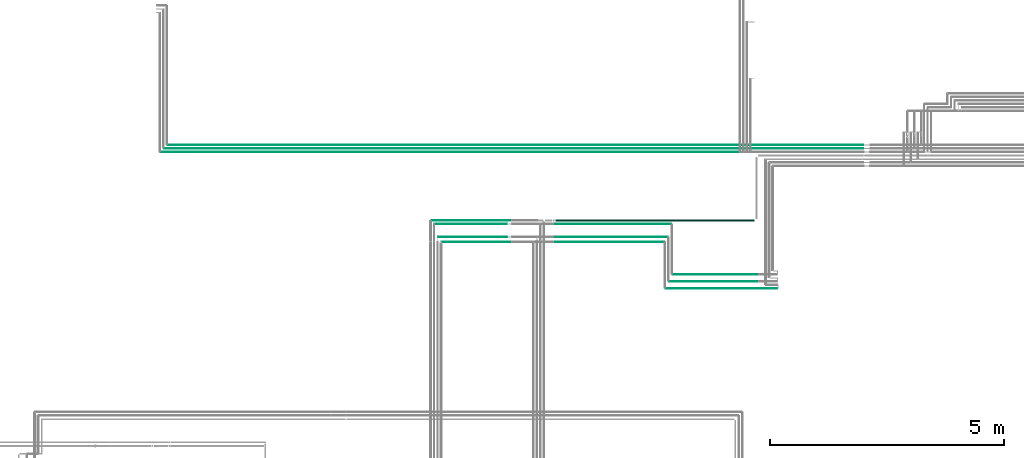
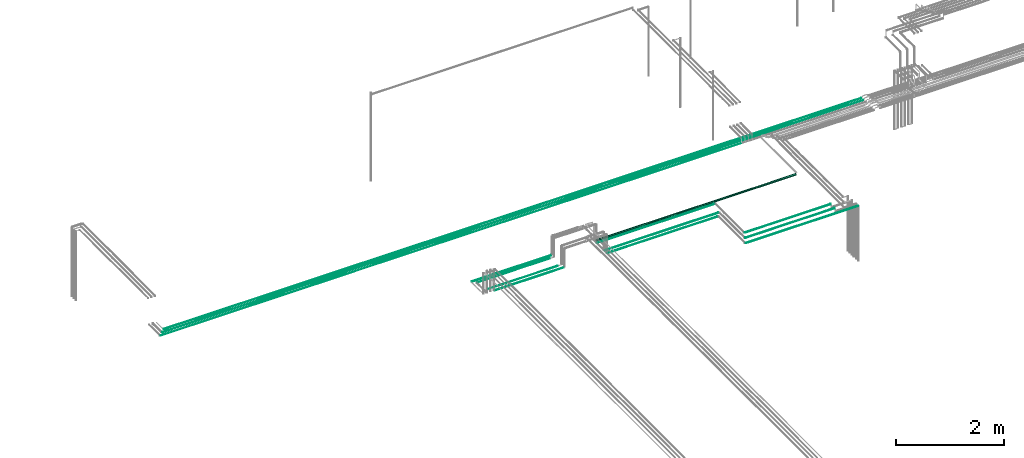
# One storey, part 23 of 331: 14 flow segments.
"""IFC2X3 building model written with IfcOpenShell, lengths in millimetres."""

import ifcopenshell
import ifcopenshell.guid

model = None  # the IFC model being written
_history = None  # IfcOwnerHistory: only IFC2X3 demands one
_inside = {}  # id of a spatial element -> (the spatial element, [elements in it])
_under = {}  # id of a project, library or spatial element -> (it, [spatial elements below it])
_declared = {}  # id of a project -> (the project, [libraries it declares])
_typed = {}  # id of a type object -> (the type object, [elements of that type])
_made_of = {}  # id of a material, layer set ... -> (it, [elements and type objects made of it])


def new_model(schema):
    """Start an empty IFC model of exactly this schema.

    Asked for "IFC4X3", IfcOpenShell would pick the latest addendum, in which some entities
    have other attributes; the version numbers below select the first issue.
    IFC2X3 requires an IfcOwnerHistory on every rooted entity: one is made here for all.
    """
    global model, _history
    if schema == "IFC4X3":
        model = ifcopenshell.file(schema_version=(4, 3, 0, 0))
    else:
        model = ifcopenshell.file(schema=schema)
    _inside.clear()
    _under.clear()
    _declared.clear()
    _typed.clear()
    _made_of.clear()
    _history = None
    if model.schema == "IFC2X3":
        org = make("IfcOrganization", Name="unknown")
        user = make(
            "IfcPersonAndOrganization",
            ThePerson=make("IfcPerson", FamilyName="unknown"),
            TheOrganization=org,
        )
        app = make(
            "IfcApplication",
            ApplicationDeveloper=org,
            Version="unknown",
            ApplicationFullName="unknown",
            ApplicationIdentifier="unknown",
        )
        _history = make(
            "IfcOwnerHistory",
            OwningUser=user,
            OwningApplication=app,
            ChangeAction="ADDED",
            CreationDate=0,
        )
    return model


def make(cls, **values):
    """One entity of the class cls with the attributes given. An attribute that is None is left unset."""
    return model.create_entity(
        cls, **{name: value for name, value in values.items() if value is not None}
    )


def entity(cls, *values):
    """Any entity or typed value of the class cls, its attributes in the order of the schema. None: left unset."""
    e = model.create_entity(cls)
    for i, value in enumerate(values):
        if value is not None:
            e[i] = value
    return e


def rooted(cls, **values):
    """An entity with a GlobalId (a new one), such as an element, a storey or a relation."""
    return make(cls, GlobalId=ifcopenshell.guid.new(), OwnerHistory=_history, **values)


def si_unit(unit_type, name, prefix=None):
    """IfcSIUnit, for example si_unit("LENGTHUNIT", "METRE", prefix="MILLI")."""
    return make("IfcSIUnit", UnitType=unit_type, Prefix=prefix, Name=name)


def converted_unit(unit_type, name, factor, base, dimensions=None, offset=None):
    """IfcConversionBasedUnit, such as the inch: factor (a typed value) times the base unit."""
    return make(
        "IfcConversionBasedUnit"
        if offset is None
        else "IfcConversionBasedUnitWithOffset",
        ConversionOffset=offset,
        Dimensions=None
        if dimensions is None
        else entity("IfcDimensionalExponents", *dimensions),
        UnitType=unit_type,
        Name=name,
        ConversionFactor=make(
            "IfcMeasureWithUnit", ValueComponent=factor, UnitComponent=base
        ),
    )


def derived_unit(unit_type, elements):
    """IfcDerivedUnit: a product of units, each with its exponent."""
    return make(
        "IfcDerivedUnit",
        Elements=[
            make("IfcDerivedUnitElement", Unit=unit, Exponent=power)
            for unit, power in elements
        ],
        UnitType=unit_type,
    )


def assignment(units):
    """IfcUnitAssignment: the units of a project."""
    return None if units is None else make("IfcUnitAssignment", Units=units)


def point(xyz):
    """IfcCartesianPoint."""
    return None if xyz is None else make("IfcCartesianPoint", Coordinates=xyz)


def direction(xyz):
    """IfcDirection."""
    return None if xyz is None else make("IfcDirection", DirectionRatios=xyz)


def frame(location, z_axis=None, x_axis=None):
    """IfcAxis2Placement3D, a coordinate frame: its origin and axes. An axis left out is left unset."""
    return make(
        "IfcAxis2Placement3D",
        Location=point(location),
        Axis=direction(z_axis),
        RefDirection=direction(x_axis),
    )


def frame_2d(location, x_axis=None):
    """IfcAxis2Placement2D, a coordinate frame in the plane: its origin and x axis."""
    return make(
        "IfcAxis2Placement2D", Location=point(location), RefDirection=direction(x_axis)
    )


def origin():
    """The frame at (0, 0, 0) with its axes left unset."""
    return frame((0.0, 0.0, 0.0))


def origin_2d_with_axis():
    """The frame at (0, 0) in the plane with the x axis (1, 0) written out."""
    return frame_2d((0.0, 0.0), x_axis=(1.0, 0.0))


def place(relative_to, where):
    """IfcLocalPlacement: puts the frame where relative to a parent placement (None: the world)."""
    return make(
        "IfcLocalPlacement", PlacementRelTo=relative_to, RelativePlacement=where
    )


def context(
    kind, dimensions, precision=None, world=None, true_north=None, identifier=None
):
    """IfcGeometricRepresentationContext, for example the 3D "Model" context."""
    return make(
        "IfcGeometricRepresentationContext",
        ContextIdentifier=identifier,
        ContextType=kind,
        CoordinateSpaceDimension=dimensions,
        Precision=precision,
        WorldCoordinateSystem=world,
        TrueNorth=true_north,
    )


def subcontext(parent, identifier, kind, view, scale=None):
    """IfcGeometricRepresentationSubContext, for example "Body" below "Model"."""
    return make(
        "IfcGeometricRepresentationSubContext",
        ContextIdentifier=identifier,
        ContextType=kind,
        ParentContext=parent,
        TargetScale=scale,
        TargetView=view,
    )


def project(units=None, contexts=None):
    """IfcProject with its units and contexts."""
    return rooted(
        "IfcProject",
        Name="project",
        RepresentationContexts=contexts,
        UnitsInContext=assignment(units),
    )


def spatial(cls, under=None, at=None, **own):
    """A site, building, storey or space (cls), placed at a placement, below another one or the project."""
    s = rooted(cls, ObjectPlacement=at, **own)
    if under is not None:
        _under.setdefault(under.id(), (under, []))[1].append(s)
    return s


def profile(cls, at=None, kind="AREA", **sizes):
    """A parametric profile (cls). Its sizes go by their IFC names, for example OverallWidth=200.0."""
    return make(cls, ProfileType=kind, Position=at, **sizes)


def circle(**sizes):
    """IfcCircleProfileDef."""
    return profile("IfcCircleProfileDef", **sizes)


def extrude(swept, where, along, depth):
    """IfcExtrudedAreaSolid: the profile swept, set in the frame where, extruded along a direction by depth."""
    return make(
        "IfcExtrudedAreaSolid",
        SweptArea=swept,
        Position=where,
        ExtrudedDirection=direction(along),
        Depth=depth,
    )


def shape(context_of_items, identifier, shape_type, items):
    """IfcShapeRepresentation: the items that make up one representation, for example the "Body"."""
    return make(
        "IfcShapeRepresentation",
        ContextOfItems=context_of_items,
        RepresentationIdentifier=identifier,
        RepresentationType=shape_type,
        Items=items,
    )


def made_of(thing, what):
    """Note that an element or type object is made of a material, layer set ...; save() writes the relation."""
    if what is not None:
        _made_of.setdefault(what.id(), (what, []))[1].append(thing)
    return thing


def type_object(cls, material=None, **own):
    """A type object (cls), such as IfcWallType, which elements share."""
    return made_of(rooted(cls, **own), material)


def element(
    cls,
    number,
    at=None,
    inside=None,
    cuts=None,
    type_object=None,
    material=None,
    context=None,
    identifier="Body",
    shape_type=None,
    held_by="IfcProductDefinitionShape",
    body=None,
    shapes=None,
    **own,
):
    """One element of the class cls, such as IfcWall. Its Tag is "e" and its number.

    at: its placement. inside: the storey or other place that contains it. cuts: it is an
    opening in that element (IfcRelVoidsElement). A single representation is given by context,
    identifier, shape_type and body (its items); several are given by shapes. held_by: the class
    of the entity that holds the representations. save() writes the other relations.
    """
    e = rooted(cls, Tag="e%d" % number, ObjectPlacement=at, **own)
    if body is not None:
        shapes = [shape(context, identifier, shape_type, body)]
    if shapes is not None:
        e.Representation = make(held_by, Representations=shapes)
    if inside is not None:
        _inside.setdefault(inside.id(), (inside, []))[1].append(e)
    if cuts is not None:
        rooted(
            "IfcRelVoidsElement", RelatingBuildingElement=cuts, RelatedOpeningElement=e
        )
    if type_object is not None:
        _typed.setdefault(type_object.id(), (type_object, []))[1].append(e)
    return made_of(e, material)


def aggregate(whole, parts):
    """IfcRelAggregates: a whole, such as a stair, and the parts it consists of."""
    return rooted("IfcRelAggregates", RelatingObject=whole, RelatedObjects=parts)


def save(model, path):
    """Write the relations noted so far, then the file.

    IfcRelAggregates (storeys below a building ...), IfcRelContainedInSpatialStructure (elements
    in a storey), IfcRelDefinesByType, IfcRelAssociatesMaterial and IfcRelDeclares: one each for
    every whole, place, type object, material and project.
    """
    for whole, parts in _under.values():
        aggregate(whole, parts)
    for where, things in _inside.values():
        rooted(
            "IfcRelContainedInSpatialStructure",
            RelatedElements=things,
            RelatingStructure=where,
        )
    for kind, things in _typed.values():
        rooted("IfcRelDefinesByType", RelatedObjects=things, RelatingType=kind)
    for what, things in _made_of.values():
        rooted("IfcRelAssociatesMaterial", RelatedObjects=things, RelatingMaterial=what)
    for by, libraries in _declared.values():
        rooted("IfcRelDeclares", RelatingContext=by, RelatedDefinitions=libraries)
    model.write(path)


model = new_model("IFC2X3")

# Units and contexts
model_context = context("Model", 3, precision=0.01, world=origin(), true_north=direction((6.12303176911189e-17, 1.0)))
body_context = subcontext(model_context, "Body", "Model", "MODEL_VIEW")
ifc_project = project(units=[si_unit("LENGTHUNIT", "METRE", prefix="MILLI"), si_unit("AREAUNIT", "SQUARE_METRE"), si_unit("VOLUMEUNIT", "CUBIC_METRE"), converted_unit("PLANEANGLEUNIT", "DEGREE", entity("IfcRatioMeasure", 0.0174532925199433), si_unit("PLANEANGLEUNIT", "RADIAN"), dimensions=[0, 0, 0, 0, 0, 0, 0]), si_unit("MASSUNIT", "GRAM", prefix="KILO"), derived_unit("MASSDENSITYUNIT", [(si_unit("MASSUNIT", "GRAM", prefix="KILO"), 1), (si_unit("LENGTHUNIT", "METRE"), -3)]), derived_unit("MOMENTOFINERTIAUNIT", [(si_unit("LENGTHUNIT", "METRE"), 4)]), si_unit("TIMEUNIT", "SECOND"), si_unit("FREQUENCYUNIT", "HERTZ"), si_unit("THERMODYNAMICTEMPERATUREUNIT", "DEGREE_CELSIUS"), derived_unit("THERMALTRANSMITTANCEUNIT", [(si_unit("MASSUNIT", "GRAM", prefix="KILO"), 1), (si_unit("THERMODYNAMICTEMPERATUREUNIT", "KELVIN"), -1), (si_unit("TIMEUNIT", "SECOND"), -3)]), derived_unit("VOLUMETRICFLOWRATEUNIT", [(si_unit("LENGTHUNIT", "METRE"), 3), (si_unit("TIMEUNIT", "SECOND"), -1)]), derived_unit("MASSFLOWRATEUNIT", [(si_unit("MASSUNIT", "GRAM", prefix="KILO"), 1), (si_unit("TIMEUNIT", "SECOND"), -1)]), derived_unit("ROTATIONALFREQUENCYUNIT", [(si_unit("TIMEUNIT", "SECOND"), -1)]), si_unit("ELECTRICCURRENTUNIT", "AMPERE"), si_unit("ELECTRICVOLTAGEUNIT", "VOLT"), si_unit("POWERUNIT", "WATT"), si_unit("FORCEUNIT", "NEWTON", prefix="KILO"), si_unit("ILLUMINANCEUNIT", "LUX"), si_unit("LUMINOUSFLUXUNIT", "LUMEN"), si_unit("LUMINOUSINTENSITYUNIT", "CANDELA"), derived_unit("USERDEFINED", [(si_unit("MASSUNIT", "GRAM", prefix="KILO"), -1), (si_unit("LENGTHUNIT", "METRE"), -2), (si_unit("TIMEUNIT", "SECOND"), 3), (si_unit("LUMINOUSFLUXUNIT", "LUMEN"), 1)]), derived_unit("LINEARVELOCITYUNIT", [(si_unit("LENGTHUNIT", "METRE"), 1), (si_unit("TIMEUNIT", "SECOND"), -1)]), si_unit("PRESSUREUNIT", "PASCAL"), derived_unit("USERDEFINED", [(si_unit("LENGTHUNIT", "METRE"), -2), (si_unit("MASSUNIT", "GRAM", prefix="KILO"), 1), (si_unit("TIMEUNIT", "SECOND"), -2)]), derived_unit("LINEARFORCEUNIT", [(si_unit("MASSUNIT", "GRAM", prefix="KILO"), 1), (si_unit("LENGTHUNIT", "METRE"), 1), (si_unit("TIMEUNIT", "SECOND"), -2), (si_unit("LENGTHUNIT", "METRE"), -1)]), derived_unit("PLANARFORCEUNIT", [(si_unit("MASSUNIT", "GRAM", prefix="KILO"), 1), (si_unit("LENGTHUNIT", "METRE"), 1), (si_unit("TIMEUNIT", "SECOND"), -2), (si_unit("LENGTHUNIT", "METRE"), -2)])], contexts=[model_context])

# Site, building, storey
site_placement = place(None, frame((0.0, -0.00077364408347762, 0.0)))
site = spatial("IfcSite", under=ifc_project, at=site_placement, CompositionType="ELEMENT")
building_placement = place(site_placement, origin())
building = spatial("IfcBuilding", under=site, at=building_placement, CompositionType="ELEMENT")
storey_placement = place(building_placement, origin())
storey = spatial("IfcBuildingStorey", under=building, at=storey_placement, CompositionType="ELEMENT", Elevation=0.0)

# Flow segments
pipe_segment_type = type_object("IfcPipeSegmentType", PredefinedType="NOTDEFINED")
flow_segment_1_placement = place(building_placement, frame((32459.0009155273, 12979.8700236546, 6742.40472776408)))
element("IfcFlowSegment", 1, at=flow_segment_1_placement, inside=storey, type_object=pipe_segment_type, context=body_context, shape_type="SweptSolid", body=[
    extrude(circle(Radius=6.0, at=frame_2d((1.08286712929839e-11, 0.0), x_axis=(1.0, 0.0))), frame((0.0, 7.59527223592753, 7.59527223591562), z_axis=(1.0, 0.0, 0.0), x_axis=(0.0, 1.0, 0.0)), (0.0, 0.0, 1.0), 2381.54556445327),
])
flow_segment_2_placement = place(building_placement, frame((32609.0009155273, 13279.8700236546, 6742.40472776409)))
element("IfcFlowSegment", 2, at=flow_segment_2_placement, inside=storey, type_object=pipe_segment_type, context=body_context, shape_type="SweptSolid", body=[
    extrude(circle(Radius=6.0, at=frame_2d((2.16573425859679e-12, 0.0), x_axis=(1.0, 0.0))), frame((0.0, 7.59527223592103, 7.59527223591562), z_axis=(1.0, 0.0, 0.0), x_axis=(0.0, 1.0, 0.0)), (0.0, 0.0, 1.0), 1821.93194868482),
])
flow_segment_3_placement = place(building_placement, frame((32534.0009155273, 13129.8700236546, 6742.4047277641)))
element("IfcFlowSegment", 3, at=flow_segment_3_placement, inside=storey, type_object=pipe_segment_type, context=body_context, shape_type="SweptSolid", body=[
    extrude(circle(Radius=6.0, at=frame_2d((4.33146851719357e-12, 0.0), x_axis=(1.0, 0.0))), frame((0.0, 7.59527223592103, 7.59527223591562), z_axis=(1.0, 0.0, 0.0), x_axis=(0.0, 1.0, 0.0)), (0.0, 0.0, 1.0), 1896.93194868482),
])
flow_segment_4_placement = place(building_placement, frame((27685.1806694985, 13977.4043981742, 6742.40472776409)))
element("IfcFlowSegment", 4, at=flow_segment_4_placement, inside=storey, type_object=pipe_segment_type, context=body_context, shape_type="SweptSolid", body=[
    extrude(circle(Radius=6.0, at=frame_2d((0.0, -1.08286712929839e-12), x_axis=(1.0, 0.0))), frame((0.0, 7.5952722359167, 7.5952722359167), z_axis=(1.0, 0.0, 0.0), x_axis=(0.0, 1.0, 0.0)), (0.0, 0.0, 1.0), 1470.81933050156),
])
flow_segment_5_placement = place(building_placement, frame((27606.2673497732, 14079.4043981742, 6744.40472776408)))
element("IfcFlowSegment", 5, at=flow_segment_5_placement, inside=storey, type_object=pipe_segment_type, context=body_context, shape_type="SweptSolid", body=[
    extrude(circle(Radius=4.0, at=origin_2d_with_axis()), frame((0.0, 5.59527223591932, 5.59527223591607), z_axis=(1.0, 0.0, 0.0), x_axis=(0.0, -1.0, 0.0)), (0.0, 0.0, 1.0), 1474.62097080566),
])
flow_segment_6_placement = place(building_placement, frame((27464.726391245, 14430.9043981742, 6740.90472776407)))
element("IfcFlowSegment", 6, at=flow_segment_6_placement, inside=storey, type_object=pipe_segment_type, context=body_context, shape_type="SweptSolid", body=[
    extrude(circle(Radius=7.5, at=origin_2d_with_axis()), frame((0.0, 9.09527223592286, 9.09527223591636), z_axis=(1.0, 0.0, 0.0), x_axis=(0.0, -1.0, 0.0)), (0.0, 0.0, 1.0), 1687.27360875504),
])
flow_segment_7_placement = place(building_placement, frame((30110.0, 14420.9043981742, 6730.90472776408)))
element("IfcFlowSegment", 7, at=flow_segment_7_placement, inside=storey, type_object=pipe_segment_type, context=body_context, shape_type="SweptSolid", body=[
    extrude(circle(Radius=17.5, at=origin_2d_with_axis()), frame((0.0, 19.0952722359163, 19.0952722359163), z_axis=(1.0, 0.0, 0.0), x_axis=(0.0, -1.0, 0.0)), (0.0, 0.0, 1.0), 4244.99758300779),
])
flow_segment_8_placement = place(building_placement, frame((30084.0, 14357.4043981742, 6742.40472776408)))
element("IfcFlowSegment", 8, at=flow_segment_8_placement, inside=storey, type_object=pipe_segment_type, context=body_context, shape_type="SweptSolid", body=[
    extrude(circle(Radius=6.0, at=origin_2d_with_axis()), frame((0.0, 7.5952722359167, 7.59527223591562), z_axis=(1.0, 0.0, 0.0), x_axis=(0.0, -1.0, 0.0)), (0.0, 0.0, 1.0), 2497.00091552733),
])
flow_segment_9_placement = place(building_placement, frame((30084.0, 13977.4043981742, 6742.40472776408)))
element("IfcFlowSegment", 9, at=flow_segment_9_placement, inside=storey, type_object=pipe_segment_type, context=body_context, shape_type="SweptSolid", body=[
    extrude(circle(Radius=6.0, at=frame_2d((-2.16573425859679e-12, 0.0), x_axis=(1.0, 0.0))), frame((0.0, 7.59527223591454, 7.59527223591562), z_axis=(1.0, 0.0, 0.0), x_axis=(0.0, -1.0, 0.0)), (0.0, 0.0, 1.0), 2347.00091552736),
])
flow_segment_10_placement = place(storey_placement, frame((21681.477472246, 15894.389397967, 6669.40472776408)))
element("IfcFlowSegment", 10, at=flow_segment_10_placement, inside=storey, type_object=pipe_segment_type, context=body_context, shape_type="SweptSolid", body=[
    extrude(circle(Radius=4.0, at=frame_2d((0.0, -1.08286712929839e-12), x_axis=(1.0, 0.0))), frame((0.0, 5.59527223591282, 5.59527223591499), z_axis=(1.0, 0.0, 0.0), x_axis=(0.0, -1.0, 0.0)), (0.0, 0.0, 1.0), 12359.0),
])
flow_segment_11_placement = place(building_placement, frame((30084.0, 14077.4043981743, 6742.40472776408)))
element("IfcFlowSegment", 11, at=flow_segment_11_placement, inside=storey, type_object=pipe_segment_type, context=body_context, shape_type="SweptSolid", body=[
    extrude(circle(Radius=6.0, at=origin_2d_with_axis()), frame((0.0, 7.5952722359167, 7.59527223591562), z_axis=(1.0, 0.0, 0.0), x_axis=(0.0, 1.0, 0.0)), (0.0, 0.0, 1.0), 2422.00091552736),
])
flow_segment_12_placement = place(storey_placement, frame((27531.6407417258, 14359.4043981742, 6744.40472776408)))
element("IfcFlowSegment", 12, at=flow_segment_12_placement, inside=storey, type_object=pipe_segment_type, context=body_context, shape_type="SweptSolid", body=[
    extrude(circle(Radius=4.0, at=origin_2d_with_axis()), frame((0.0, 5.59527223592365, 5.59527223591607), z_axis=(1.0, 0.0, 0.0), x_axis=(0.0, -1.0, 0.0)), (0.0, 0.0, 1.0), 1543.24757885303),
])
flow_segment_13_placement = place(storey_placement, frame((21760.477472246, 15967.389397967, 6667.40472776408)))
element("IfcFlowSegment", 13, at=flow_segment_13_placement, inside=storey, type_object=pipe_segment_type, context=body_context, shape_type="SweptSolid", body=[
    extrude(circle(Radius=6.0, at=frame_2d((0.0, -1.08286712929839e-12), x_axis=(1.0, 0.0))), frame((0.0, 7.5952722359167, 7.59527223591454), z_axis=(1.0, 0.0, 0.0), x_axis=(0.0, -1.0, 0.0)), (0.0, 0.0, 1.0), 14918.9319439975),
])
flow_segment_14_placement = place(storey_placement, frame((21835.477472246, 16042.389397967, 6667.40472776408)))
element("IfcFlowSegment", 14, at=flow_segment_14_placement, inside=storey, type_object=pipe_segment_type, context=body_context, shape_type="SweptSolid", body=[
    extrude(circle(Radius=6.0, at=frame_2d((0.0, -1.08286712929839e-12), x_axis=(1.0, 0.0))), frame((0.0, 7.59527223591887, 7.59527223591454), z_axis=(1.0, 0.0, 0.0), x_axis=(0.0, -1.0, 0.0)), (0.0, 0.0, 1.0), 14843.9319439975),
])

save(model, "model.ifc")
